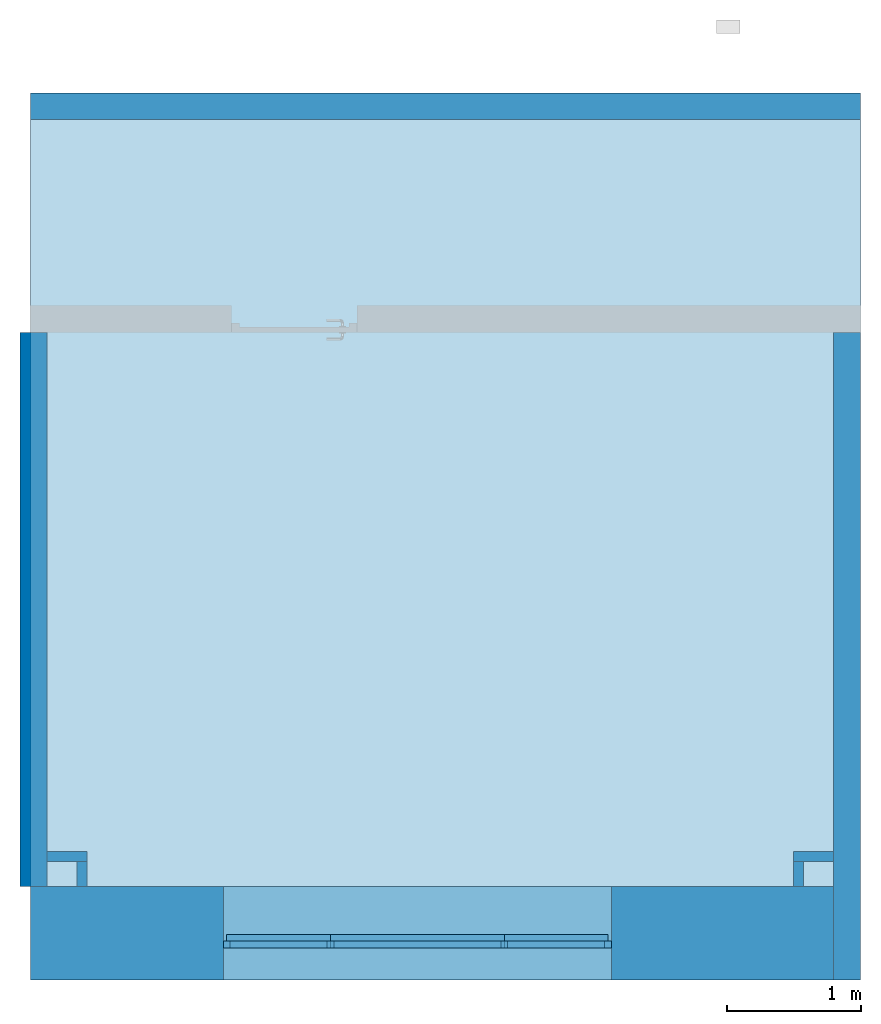
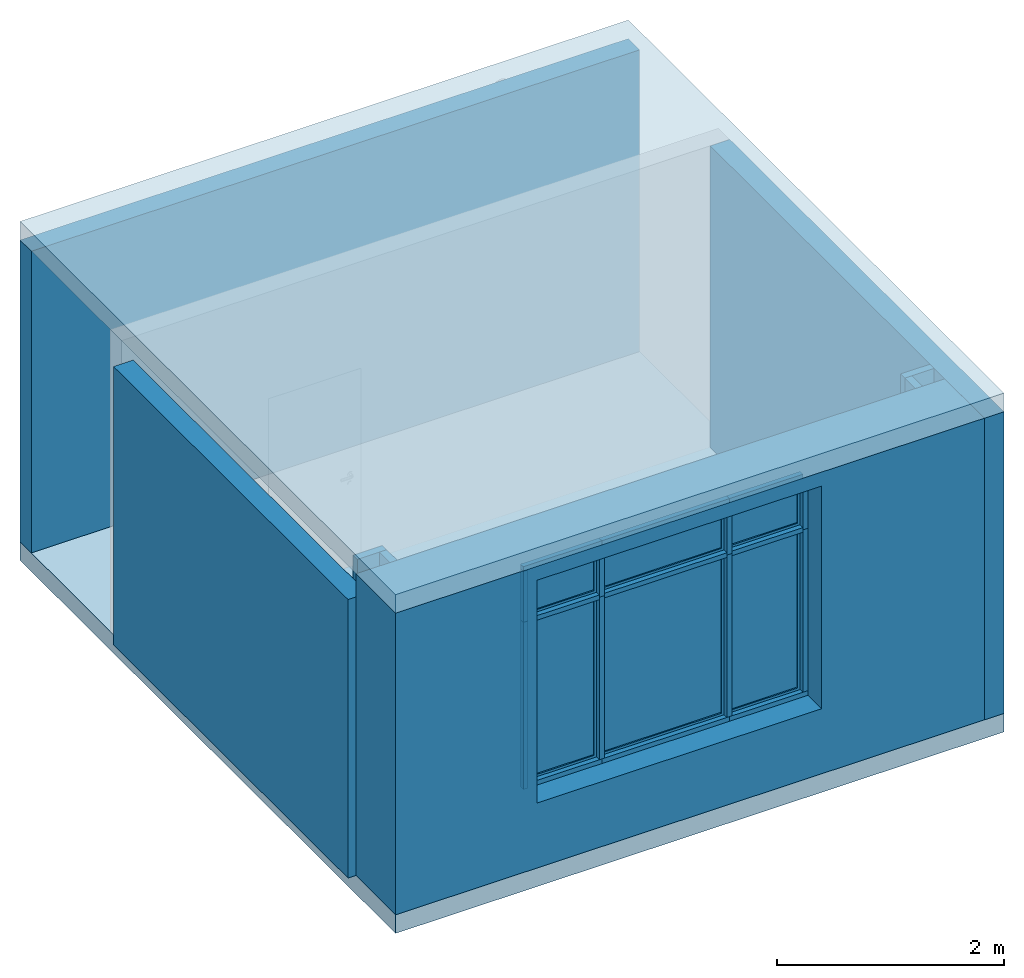
# One storey, part 1 of 4: 17 members, 8 walls, 6 plates, 2 slabs, 1 opening, 1 element without a shape of its own.
"""IFC2X3 building model written with IfcOpenShell, lengths in millimetres."""

from ifc_helpers import new_model, entity, si_unit, converted_unit, derived_unit, direction, frame, frame_2d, origin, origin_2d_with_axis, place, context, subcontext, project, spatial, polyline, rectangle, outline, extrude, clip, bounded_halfspace, source, transform, mapped, material, material_list, layer, layer_set, layer_usage, type_object, type_shapes, element, aggregate, save


model = new_model("IFC2X3")

# Units and contexts
model_context = context("Model", 3, precision=0.01, world=origin(), true_north=direction((6.123233995736766e-17, 1.0)))
body_context = subcontext(model_context, "Body", "Model", "MODEL_VIEW")
ifc_project = project(units=[si_unit("LENGTHUNIT", "METRE", prefix="MILLI"), si_unit("AREAUNIT", "SQUARE_METRE"), si_unit("VOLUMEUNIT", "CUBIC_METRE"), converted_unit("PLANEANGLEUNIT", "DEGREE", entity("IfcPlaneAngleMeasure", 0.017453292519943278), si_unit("PLANEANGLEUNIT", "RADIAN"), dimensions=[0, 0, 0, 0, 0, 0, 0]), derived_unit("THERMALTRANSMITTANCEUNIT", [(si_unit("MASSUNIT", "GRAM", prefix="KILO"), 1), (si_unit("THERMODYNAMICTEMPERATUREUNIT", "KELVIN"), -1), (si_unit("TIMEUNIT", "SECOND"), -3)])], contexts=[model_context])

# Site, building, storey
site_placement = place(None, origin())
site = spatial("IfcSite", under=ifc_project, at=site_placement, CompositionType="ELEMENT")
building_placement = place(site_placement, origin())
building = spatial("IfcBuilding", under=site, at=building_placement, CompositionType="ELEMENT")
storey_placement = place(building_placement, origin())
storey = spatial("IfcBuildingStorey", under=building, at=storey_placement, CompositionType="ELEMENT", Elevation=0.0)

# Curtain wall, members
curtain_wall_type = type_object("IfcCurtainWallType", PredefinedType="NOTDEFINED")
curtain_wall_placement = place(storey_placement, origin())
curtain_wall = element("IfcCurtainWall", 1, at=curtain_wall_placement, inside=storey, type_object=curtain_wall_type)
ifc_material_1 = material(Name="Aluminium, RAL 7021")
member_type_1 = type_object("IfcMemberType", Name="Rectangular Mullion:50x50, RAL 7021", PredefinedType="MULLION", material=ifc_material_1)
shared_shape_1 = source(origin(), body_context, "Body", "SweptSolid", [
    extrude(rectangle(XDim=50.0, YDim=50.000000000000014, at=origin_2d_with_axis()), frame((-25.0, 0.0, -750.0), z_axis=(0.0, 0.0, 1.0), x_axis=(-1.0, 0.0, 0.0)), (0.0, 0.0, 1.0), 750.0),
])
type_shapes(member_type_1, [shared_shape_1])
member_1_placement = place(curtain_wall_placement, frame((10300.0, -435.0, 3100.0), z_axis=(1.0, 0.0, 0.0), x_axis=(0.0, 0.0, 1.0)))
member_1 = element("IfcMember", 2, at=member_1_placement, type_object=member_type_1, material=ifc_material_1, Name="Rectangular Mullion:50x50, RAL 7021", ObjectType="Rectangular Mullion:50x50, RAL 7021", context=body_context, shape_type="MappedRepresentation", body=[
    mapped(shared_shape_1, transform((0.0, 0.0, 0.0), scale=1.0)),
])
member_type_2 = type_object("IfcMemberType", Name="Rectangular Mullion:50x50, RAL 7021", PredefinedType="MULLION", material=ifc_material_1)
shared_shape_2 = source(origin(), body_context, "Body", "SweptSolid", [
    extrude(rectangle(XDim=50.0, YDim=50.000000000000014, at=origin_2d_with_axis()), frame((-25.0, 0.0, -750.0), z_axis=(0.0, 0.0, 1.0), x_axis=(-1.0, 0.0, 0.0)), (0.0, 0.0, 1.0), 750.0),
])
type_shapes(member_type_2, [shared_shape_2])
member_2_placement = place(curtain_wall_placement, frame((7500.0, -435.0, 700.0), z_axis=(-1.0, 0.0, 0.0), x_axis=(0.0, 0.0, -1.0)))
member_2 = element("IfcMember", 3, at=member_2_placement, type_object=member_type_2, material=ifc_material_1, Name="Rectangular Mullion:50x50, RAL 7021", ObjectType="Rectangular Mullion:50x50, RAL 7021", context=body_context, shape_type="MappedRepresentation", body=[
    mapped(shared_shape_2, transform((0.0, 0.0, 0.0), scale=1.0)),
])
member_type_3 = type_object("IfcMemberType", Name="Rectangular Mullion:50x50, RAL 7021", PredefinedType="MULLION", material=ifc_material_1)
shared_shape_3 = source(origin(), body_context, "Body", "SweptSolid", [
    extrude(rectangle(XDim=50.0, YDim=50.000000000000014, at=origin_2d_with_axis()), frame((-25.0, 0.0, -1750.0), z_axis=(0.0, 0.0, 1.0), x_axis=(-1.0, 0.0, 0.0)), (0.0, 0.0, 1.0), 1750.0000000000002),
])
type_shapes(member_type_3, [shared_shape_3])
member_3_placement = place(curtain_wall_placement, frame((10350.0, -435.0, 750.0), z_axis=(0.0, 0.0, -1.0), x_axis=(1.0, 0.0, 0.0)))
member_3 = element("IfcMember", 4, at=member_3_placement, type_object=member_type_3, material=ifc_material_1, Name="Rectangular Mullion:50x50, RAL 7021", ObjectType="Rectangular Mullion:50x50, RAL 7021", context=body_context, shape_type="MappedRepresentation", body=[
    mapped(shared_shape_3, transform((0.0, 0.0, 0.0), scale=1.0)),
])
member_type_4 = type_object("IfcMemberType", Name="Rectangular Mullion:50x50, RAL 7021", PredefinedType="MULLION", material=ifc_material_1)
shared_shape_4 = source(origin(), body_context, "Body", "SweptSolid", [
    extrude(rectangle(XDim=50.0, YDim=50.0, at=origin_2d_with_axis()), frame((-25.0, 0.0, -550.0), z_axis=(0.0, 0.0, 1.0), x_axis=(-1.0, 0.0, 0.0)), (0.0, 0.0, 1.0), 550.0),
])
type_shapes(member_type_4, [shared_shape_4])
member_4_placement = place(curtain_wall_placement, frame((7450.0, -435.0, 3050.0), z_axis=(0.0, 0.0, 1.0), x_axis=(-1.0, 0.0, 0.0)))
member_4 = element("IfcMember", 5, at=member_4_placement, type_object=member_type_4, material=ifc_material_1, Name="Rectangular Mullion:50x50, RAL 7021", ObjectType="Rectangular Mullion:50x50, RAL 7021", context=body_context, shape_type="MappedRepresentation", body=[
    mapped(shared_shape_4, transform((0.0, 0.0, 0.0), scale=1.0)),
])
member_type_5 = type_object("IfcMemberType", Name="Rectangular Mullion:50x50, RAL 7021", PredefinedType="MULLION", material=ifc_material_1)
shared_shape_5 = source(origin(), body_context, "Body", "SweptSolid", [
    extrude(rectangle(XDim=50.0, YDim=50.000000000000014, at=origin_2d_with_axis()), frame((-25.0, 0.0, -600.0), z_axis=(0.0, 0.0, 1.0), x_axis=(-1.0, 0.0, 0.0)), (0.0, 0.0, 1.0), 600.0),
])
type_shapes(member_type_5, [shared_shape_5])
member_5_placement = place(curtain_wall_placement, frame((10350.0, -435.0, 2500.0), z_axis=(0.0, 0.0, -1.0), x_axis=(1.0, 0.0, 0.0)))
member_5 = element("IfcMember", 6, at=member_5_placement, type_object=member_type_5, material=ifc_material_1, Name="Rectangular Mullion:50x50, RAL 7021", ObjectType="Rectangular Mullion:50x50, RAL 7021", context=body_context, shape_type="MappedRepresentation", body=[
    mapped(shared_shape_5, transform((0.0, 0.0, 0.0), scale=1.0)),
])
member_type_6 = type_object("IfcMemberType", Name="Rectangular Mullion:50x50, RAL 7021", PredefinedType="MULLION", material=ifc_material_1)
shared_shape_6 = source(origin(), body_context, "Body", "SweptSolid", [
    extrude(rectangle(XDim=50.0, YDim=50.0, at=origin_2d_with_axis()), frame((-25.0, 0.0, -1800.0), z_axis=(0.0, 0.0, 1.0), x_axis=(-1.0, 0.0, 0.0)), (0.0, 0.0, 1.0), 1800.0000000000002),
])
type_shapes(member_type_6, [shared_shape_6])
member_6_placement = place(curtain_wall_placement, frame((7450.0, -435.0, 2500.0), z_axis=(0.0, 0.0, 1.0), x_axis=(-1.0, 0.0, 0.0)))
member_6 = element("IfcMember", 7, at=member_6_placement, type_object=member_type_6, material=ifc_material_1, Name="Rectangular Mullion:50x50, RAL 7021", ObjectType="Rectangular Mullion:50x50, RAL 7021", context=body_context, shape_type="MappedRepresentation", body=[
    mapped(shared_shape_6, transform((0.0, 0.0, 0.0), scale=1.0)),
])
member_type_7 = type_object("IfcMemberType", Name="Rectangular Mullion:50x50, RAL 7021", PredefinedType="MULLION", material=ifc_material_1)
shared_shape_7 = source(origin(), body_context, "Body", "SweptSolid", [
    extrude(rectangle(XDim=50.0, YDim=50.0, at=frame_2d((0.0, 1.7763568394002505e-15), x_axis=(1.0, 0.0))), frame((0.0, 0.0, -725.0), z_axis=(0.0, 0.0, 1.0), x_axis=(-1.0, 0.0, 0.0)), (0.0, 0.0, 1.0), 725.0),
])
type_shapes(member_type_7, [shared_shape_7])
member_7_placement = place(curtain_wall_placement, frame((8225.0, -435.0, 2500.0), z_axis=(1.0, 0.0, 0.0), x_axis=(0.0, 0.0, 1.0)))
member_7 = element("IfcMember", 8, at=member_7_placement, type_object=member_type_7, material=ifc_material_1, Name="Rectangular Mullion:50x50, RAL 7021", ObjectType="Rectangular Mullion:50x50, RAL 7021", context=body_context, shape_type="MappedRepresentation", body=[
    mapped(shared_shape_7, transform((0.0, 0.0, 0.0), scale=1.0)),
])
member_8_placement = place(curtain_wall_placement, frame((10300.0, -435.0, 2500.0), z_axis=(1.0, 0.0, 0.0), x_axis=(0.0, 0.0, 1.0)))
member_8 = element("IfcMember", 9, at=member_8_placement, type_object=member_type_7, material=ifc_material_1, Name="Rectangular Mullion:50x50, RAL 7021", ObjectType="Rectangular Mullion:50x50, RAL 7021", context=body_context, shape_type="MappedRepresentation", body=[
    mapped(shared_shape_7, transform((0.0, 0.0, 0.0), scale=1.0)),
])
member_type_8 = type_object("IfcMemberType", Name="Rectangular Mullion:50x50, RAL 7021", PredefinedType="MULLION", material=ifc_material_1)
shared_shape_8 = source(origin(), body_context, "Body", "SweptSolid", [
    extrude(rectangle(XDim=50.0, YDim=50.000000000000014, at=origin_2d_with_axis()), frame((-25.0, 0.0, -800.0), z_axis=(0.0, 0.0, 1.0), x_axis=(-1.0, 0.0, 0.0)), (0.0, 0.0, 1.0), 800.0),
])
type_shapes(member_type_8, [shared_shape_8])
member_9_placement = place(curtain_wall_placement, frame((8250.0, -435.0, 3100.0), z_axis=(1.0, 0.0, 0.0), x_axis=(0.0, 0.0, 1.0)))
member_9 = element("IfcMember", 10, at=member_9_placement, type_object=member_type_8, material=ifc_material_1, Name="Rectangular Mullion:50x50, RAL 7021", ObjectType="Rectangular Mullion:50x50, RAL 7021", context=body_context, shape_type="MappedRepresentation", body=[
    mapped(shared_shape_8, transform((0.0, 0.0, 0.0), scale=1.0)),
])
member_type_9 = type_object("IfcMemberType", Name="Rectangular Mullion:50x50, RAL 7021", PredefinedType="MULLION", material=ifc_material_1)
shared_shape_9 = source(origin(), body_context, "Body", "SweptSolid", [
    extrude(rectangle(XDim=50.0, YDim=50.000000000000014, at=origin_2d_with_axis()), frame((-25.0, 0.0, -1300.0), z_axis=(0.0, 0.0, 1.0), x_axis=(-1.0, 0.0, 0.0)), (0.0, 0.0, 1.0), 1300.0),
])
type_shapes(member_type_9, [shared_shape_9])
member_10_placement = place(curtain_wall_placement, frame((8250.0, -435.0, 700.0), z_axis=(-1.0, 0.0, 0.0), x_axis=(0.0, 0.0, -1.0)))
member_10 = element("IfcMember", 11, at=member_10_placement, type_object=member_type_9, material=ifc_material_1, Name="Rectangular Mullion:50x50, RAL 7021", ObjectType="Rectangular Mullion:50x50, RAL 7021", context=body_context, shape_type="MappedRepresentation", body=[
    mapped(shared_shape_9, transform((0.0, 0.0, 0.0), scale=1.0)),
])
member_type_10 = type_object("IfcMemberType", Name="Rectangular Mullion:50x50, RAL 7021", PredefinedType="MULLION", material=ifc_material_1)
shared_shape_10 = source(origin(), body_context, "Body", "SweptSolid", [
    extrude(rectangle(XDim=50.0, YDim=50.0, at=frame_2d((0.0, 1.7763568394002505e-15), x_axis=(1.0, 0.0))), frame((0.0, 0.0, -1250.0), z_axis=(0.0, 0.0, 1.0), x_axis=(-1.0, 0.0, 0.0)), (0.0, 0.0, 1.0), 1250.0),
])
type_shapes(member_type_10, [shared_shape_10])
member_11_placement = place(curtain_wall_placement, frame((9525.0, -435.0, 2500.0), z_axis=(1.0, 0.0, 0.0), x_axis=(0.0, 0.0, 1.0)))
member_11 = element("IfcMember", 12, at=member_11_placement, type_object=member_type_10, material=ifc_material_1, Name="Rectangular Mullion:50x50, RAL 7021", ObjectType="Rectangular Mullion:50x50, RAL 7021", context=body_context, shape_type="MappedRepresentation", body=[
    mapped(shared_shape_10, transform((0.0, 0.0, 0.0), scale=1.0)),
])
member_type_11 = type_object("IfcMemberType", Name="Rectangular Mullion:50x50, RAL 7021", PredefinedType="MULLION", material=ifc_material_1)
shared_shape_11 = source(origin(), body_context, "Body", "SweptSolid", [
    extrude(rectangle(XDim=50.0, YDim=50.0, at=origin_2d_with_axis()), frame((0.0, 0.0, -1750.0), z_axis=(0.0, 0.0, 1.0), x_axis=(-1.0, 0.0, 0.0)), (0.0, 0.0, 1.0), 1750.0000000000002),
])
type_shapes(member_type_11, [shared_shape_11])
member_12_placement = place(curtain_wall_placement, frame((8250.0, -435.0, 750.0), z_axis=(0.0, 0.0, -1.0), x_axis=(1.0, 0.0, 0.0)))
member_12 = element("IfcMember", 13, at=member_12_placement, type_object=member_type_11, material=ifc_material_1, Name="Rectangular Mullion:50x50, RAL 7021", ObjectType="Rectangular Mullion:50x50, RAL 7021", context=body_context, shape_type="MappedRepresentation", body=[
    mapped(shared_shape_11, transform((0.0, 0.0, 0.0), scale=1.0)),
])
member_13_placement = place(curtain_wall_placement, frame((9550.0, -435.0, 750.0), z_axis=(0.0, 0.0, -1.0), x_axis=(1.0, 0.0, 0.0)))
member_13 = element("IfcMember", 14, at=member_13_placement, type_object=member_type_11, material=ifc_material_1, Name="Rectangular Mullion:50x50, RAL 7021", ObjectType="Rectangular Mullion:50x50, RAL 7021", context=body_context, shape_type="MappedRepresentation", body=[
    mapped(shared_shape_11, transform((0.0, 0.0, 0.0), scale=1.0)),
])
member_type_12 = type_object("IfcMemberType", Name="Rectangular Mullion:50x50, RAL 7021", PredefinedType="MULLION", material=ifc_material_1)
shared_shape_12 = source(origin(), body_context, "Body", "SweptSolid", [
    extrude(rectangle(XDim=50.0, YDim=50.0, at=origin_2d_with_axis()), frame((0.0, 0.0, -550.0), z_axis=(0.0, 0.0, 1.0), x_axis=(-1.0, 0.0, 0.0)), (0.0, 0.0, 1.0), 550.0),
])
type_shapes(member_type_12, [shared_shape_12])
member_14_placement = place(curtain_wall_placement, frame((8250.0, -435.0, 2500.0), z_axis=(0.0, 0.0, -1.0), x_axis=(1.0, 0.0, 0.0)))
member_14 = element("IfcMember", 15, at=member_14_placement, type_object=member_type_12, material=ifc_material_1, Name="Rectangular Mullion:50x50, RAL 7021", ObjectType="Rectangular Mullion:50x50, RAL 7021", context=body_context, shape_type="MappedRepresentation", body=[
    mapped(shared_shape_12, transform((0.0, 0.0, 0.0), scale=1.0)),
])
member_15_placement = place(curtain_wall_placement, frame((9550.0, -435.0, 2500.0), z_axis=(0.0, 0.0, -1.0), x_axis=(1.0, 0.0, 0.0)))
member_15 = element("IfcMember", 16, at=member_15_placement, type_object=member_type_12, material=ifc_material_1, Name="Rectangular Mullion:50x50, RAL 7021", ObjectType="Rectangular Mullion:50x50, RAL 7021", context=body_context, shape_type="MappedRepresentation", body=[
    mapped(shared_shape_12, transform((0.0, 0.0, 0.0), scale=1.0)),
])
member_type_13 = type_object("IfcMemberType", Name="Rectangular Mullion:50x50, RAL 7021", PredefinedType="MULLION", material=ifc_material_1)
shared_shape_13 = source(origin(), body_context, "Body", "SweptSolid", [
    extrude(rectangle(XDim=50.0, YDim=50.000000000000014, at=origin_2d_with_axis()), frame((-25.0, 0.0, -1300.0), z_axis=(0.0, 0.0, 1.0), x_axis=(-1.0, 0.0, 0.0)), (0.0, 0.0, 1.0), 1300.0),
])
type_shapes(member_type_13, [shared_shape_13])
member_16_placement = place(curtain_wall_placement, frame((9550.0, -435.0, 3100.0), z_axis=(1.0, 0.0, 0.0), x_axis=(0.0, 0.0, 1.0)))
member_16 = element("IfcMember", 17, at=member_16_placement, type_object=member_type_13, material=ifc_material_1, Name="Rectangular Mullion:50x50, RAL 7021", ObjectType="Rectangular Mullion:50x50, RAL 7021", context=body_context, shape_type="MappedRepresentation", body=[
    mapped(shared_shape_13, transform((0.0, 0.0, 0.0), scale=1.0)),
])
member_type_14 = type_object("IfcMemberType", Name="Rectangular Mullion:50x50, RAL 7021", PredefinedType="MULLION", material=ifc_material_1)
shared_shape_14 = source(origin(), body_context, "Body", "SweptSolid", [
    extrude(rectangle(XDim=50.0, YDim=50.000000000000014, at=origin_2d_with_axis()), frame((-25.0, 0.0, -800.0), z_axis=(0.0, 0.0, 1.0), x_axis=(-1.0, 0.0, 0.0)), (0.0, 0.0, 1.0), 800.0),
])
type_shapes(member_type_14, [shared_shape_14])
member_17_placement = place(curtain_wall_placement, frame((9550.0, -435.0, 700.0), z_axis=(-1.0, 0.0, 0.0), x_axis=(0.0, 0.0, -1.0)))
member_17 = element("IfcMember", 18, at=member_17_placement, type_object=member_type_14, material=ifc_material_1, Name="Rectangular Mullion:50x50, RAL 7021", ObjectType="Rectangular Mullion:50x50, RAL 7021", context=body_context, shape_type="MappedRepresentation", body=[
    mapped(shared_shape_14, transform((0.0, 0.0, 0.0), scale=1.0)),
])

# Slabs
ifc_material_2 = material()
ifc_layer_1 = layer(ifc_material_2, 200.0)
ifc_layer_set_1 = layer_set([ifc_layer_1])
ifc_layer_usage_1 = layer_usage(ifc_layer_set_1, "AXIS3", "POSITIVE", 0.0)
slab_type = type_object("IfcSlabType", PredefinedType="FLOOR", material=ifc_layer_set_1)
slab_1_placement = place(storey_placement, origin())
element("IfcSlab", 19, at=slab_1_placement, inside=storey, type_object=slab_type, material=ifc_layer_usage_1, PredefinedType="FLOOR", context=body_context, shape_type="SweptSolid", body=[
    extrude(rectangle(XDim=6630.000000000012, YDim=6200.000000000009, at=frame_2d((0.0, 1.1368683772161603e-12), x_axis=(1.0, 0.0))), frame((9110.0, 2615.0, 3450.0), z_axis=(0.0, 0.0, -1.0), x_axis=(0.0, 1.0, 0.0)), (0.0, 0.0, 1.0), 200.0),
])
ifc_layer_usage_2 = layer_usage(ifc_layer_set_1, "AXIS3", "POSITIVE", 0.0)
slab_2_placement = place(storey_placement, origin())
element("IfcSlab", 20, at=slab_2_placement, inside=storey, type_object=slab_type, material=ifc_layer_usage_2, PredefinedType="FLOOR", context=body_context, shape_type="SweptSolid", body=[
    extrude(rectangle(XDim=6630.000000000012, YDim=6200.000000000009, at=frame_2d((0.0, 1.1368683772161603e-12), x_axis=(1.0, 0.0))), frame((9110.0, 2615.0, 0.0), z_axis=(0.0, 0.0, -1.0), x_axis=(0.0, 1.0, 0.0)), (0.0, 0.0, 1.0), 200.0),
])

# Plate
ifc_material_3 = material(Name="Glass")
ifc_material_list = material_list([ifc_material_1, ifc_material_3])
plate_type_1 = type_object("IfcPlateType", Name="Casement panel:50x50, RAL 7021", PredefinedType="CURTAIN_PANEL", material=ifc_material_list)
shared_shape_15 = source(origin(), body_context, "Body", "SweptSolid", [
    extrude(outline(polyline([(-387.4999999999808, -887.4999999999947), (387.4999999999808, -887.4999999999947), (387.4999999999808, 887.4999999999947), (-387.4999999999808, 887.4999999999947), (-387.4999999999808, -887.4999999999947)]), holes=[polyline([(337.49999999998084, -837.4999999999917), (-337.4999999999802, -837.4999999999917), (-337.4999999999801, 837.4999999999957), (337.4999999999808, 837.4999999999957), (337.49999999998084, -837.4999999999917)])]), frame((0.0, 25.0, 862.4999999999984), z_axis=(0.0, 1.0, 0.0), x_axis=(-1.0, 0.0, 0.0)), (0.0, 0.0, 1.0), 50.0),
    extrude(rectangle(XDim=5.000000000000005, YDim=674.9999999999611, at=frame_2d((-4.218847493575595e-15, -5.684341886080802e-14), x_axis=(1.0, 0.0))), frame((0.0, 41.666666666664774, 25.0), z_axis=(0.0, 0.0, 1.0), x_axis=(0.0, 1.0, 0.0)), (0.0, 0.0, 1.0), 1674.9999999999877),
    extrude(rectangle(XDim=4.999999999999997, YDim=674.9999999999611, at=frame_2d((8.43769498715119e-15, -5.684341886080802e-14), x_axis=(1.0, 0.0))), frame((0.0, 58.33333333333141, 25.0), z_axis=(0.0, 0.0, 1.0), x_axis=(0.0, 1.0, 0.0)), (0.0, 0.0, 1.0), 1674.9999999999877),
])
type_shapes(plate_type_1, [shared_shape_15])
plate_1_placement = place(curtain_wall_placement, frame((7862.50000000001, -435.0, 750.0)))
plate_1 = element("IfcPlate", 21, at=plate_1_placement, type_object=plate_type_1, material=ifc_material_list, Name="Casement panel:50x50, RAL 7021", ObjectType="Casement panel:50x50, RAL 7021", context=body_context, shape_type="MappedRepresentation", body=[
    mapped(shared_shape_15, transform((0.0, 0.0, 0.0), scale=1.0)),
])

plate_2_placement = place(curtain_wall_placement, frame((9937.500000000011, -435.0, 750.0)))
plate_2 = element("IfcPlate", 22, at=plate_2_placement, type_object=plate_type_1, material=ifc_material_list, Name="Casement panel:50x50, RAL 7021", ObjectType="Casement panel:50x50, RAL 7021", context=body_context, shape_type="MappedRepresentation", body=[
    mapped(shared_shape_15, transform((0.0, 0.0, 0.0), scale=1.0)),
])

plate_type_2 = type_object("IfcPlateType", Name="Casement panel:50x50, RAL 7021", PredefinedType="CURTAIN_PANEL", material=ifc_material_list)
shared_shape_16 = source(origin(), body_context, "Body", "SweptSolid", [
    extrude(outline(polyline([(-650.0, -887.4999999999947), (650.0, -887.4999999999947), (650.0, 887.4999999999947), (-650.0, 887.4999999999947), (-650.0, -887.4999999999947)]), holes=[polyline([(600.0, -837.4999999999917), (-600.0, -837.4999999999917), (-600.0, 837.4999999999957), (600.0, 837.4999999999957), (600.0, -837.4999999999917)])]), frame((0.0, 25.0, 862.4999999999984), z_axis=(0.0, 1.0, 0.0), x_axis=(-1.0, 0.0, 0.0)), (0.0, 0.0, 1.0), 50.0),
    extrude(rectangle(XDim=5.000000000000005, YDim=1199.9999999999611, at=frame_2d((-4.218847493575595e-15, 0.0), x_axis=(1.0, 0.0))), frame((0.0, 41.666666666664774, 25.0), z_axis=(0.0, 0.0, 1.0), x_axis=(0.0, 1.0, 0.0)), (0.0, 0.0, 1.0), 1674.9999999999877),
    extrude(rectangle(XDim=4.999999999999997, YDim=1199.9999999999611, at=frame_2d((8.43769498715119e-15, 0.0), x_axis=(1.0, 0.0))), frame((0.0, 58.33333333333141, 25.0), z_axis=(0.0, 0.0, 1.0), x_axis=(0.0, 1.0, 0.0)), (0.0, 0.0, 1.0), 1674.9999999999877),
])
type_shapes(plate_type_2, [shared_shape_16])
plate_3_placement = place(curtain_wall_placement, frame((8900.0, -435.0, 750.0)))
plate_3 = element("IfcPlate", 23, at=plate_3_placement, type_object=plate_type_2, material=ifc_material_list, Name="Casement panel:50x50, RAL 7021", ObjectType="Casement panel:50x50, RAL 7021", context=body_context, shape_type="MappedRepresentation", body=[
    mapped(shared_shape_16, transform((0.0, 0.0, 0.0), scale=1.0)),
])

plate_type_3 = type_object("IfcPlateType", Name="Casement panel:50x50, RAL 7021", PredefinedType="CURTAIN_PANEL", material=ifc_material_list)
shared_shape_17 = source(origin(), body_context, "Body", "SweptSolid", [
    extrude(outline(polyline([(-387.4999999999808, -287.4999999999946), (387.4999999999808, -287.4999999999946), (387.4999999999808, 287.4999999999946), (-387.4999999999808, 287.4999999999946), (-387.4999999999808, -287.4999999999946)]), holes=[polyline([(337.49999999998084, -237.49999999999176), (-337.4999999999802, -237.49999999999176), (-337.4999999999801, 237.49999999999568), (337.4999999999808, 237.49999999999568), (337.49999999998084, -237.49999999999176)])]), frame((0.0, 25.0, 262.49999999999847), z_axis=(0.0, 1.0, 0.0), x_axis=(-1.0, 0.0, 0.0)), (0.0, 0.0, 1.0), 50.0),
    extrude(rectangle(XDim=5.000000000000005, YDim=674.9999999999611, at=frame_2d((-4.218847493575595e-15, -5.684341886080802e-14), x_axis=(1.0, 0.0))), frame((0.0, 41.666666666664774, 25.0), z_axis=(0.0, 0.0, 1.0), x_axis=(0.0, 1.0, 0.0)), (0.0, 0.0, 1.0), 474.99999999998755),
    extrude(rectangle(XDim=4.999999999999997, YDim=674.9999999999611, at=frame_2d((8.43769498715119e-15, -5.684341886080802e-14), x_axis=(1.0, 0.0))), frame((0.0, 58.33333333333141, 25.0), z_axis=(0.0, 0.0, 1.0), x_axis=(0.0, 1.0, 0.0)), (0.0, 0.0, 1.0), 474.99999999998755),
])
type_shapes(plate_type_3, [shared_shape_17])
plate_4_placement = place(curtain_wall_placement, frame((7862.50000000001, -435.0, 2525.0)))
plate_4 = element("IfcPlate", 24, at=plate_4_placement, type_object=plate_type_3, material=ifc_material_list, Name="Casement panel:50x50, RAL 7021", ObjectType="Casement panel:50x50, RAL 7021", context=body_context, shape_type="MappedRepresentation", body=[
    mapped(shared_shape_17, transform((0.0, 0.0, 0.0), scale=1.0)),
])

plate_5_placement = place(curtain_wall_placement, frame((9937.500000000011, -435.0, 2525.0)))
plate_5 = element("IfcPlate", 25, at=plate_5_placement, type_object=plate_type_3, material=ifc_material_list, Name="Casement panel:50x50, RAL 7021", ObjectType="Casement panel:50x50, RAL 7021", context=body_context, shape_type="MappedRepresentation", body=[
    mapped(shared_shape_17, transform((0.0, 0.0, 0.0), scale=1.0)),
])

plate_type_4 = type_object("IfcPlateType", Name="Casement panel:50x50, RAL 7021", PredefinedType="CURTAIN_PANEL", material=ifc_material_list)
shared_shape_18 = source(origin(), body_context, "Body", "SweptSolid", [
    extrude(outline(polyline([(-650.0, -287.4999999999946), (650.0, -287.4999999999946), (650.0, 287.4999999999946), (-650.0, 287.4999999999946), (-650.0, -287.4999999999946)]), holes=[polyline([(600.0, -237.49999999999176), (-600.0, -237.49999999999176), (-600.0, 237.49999999999568), (600.0, 237.49999999999568), (600.0, -237.49999999999176)])]), frame((0.0, 25.0, 262.49999999999847), z_axis=(0.0, 1.0, 0.0), x_axis=(-1.0, 0.0, 0.0)), (0.0, 0.0, 1.0), 50.0),
    extrude(rectangle(XDim=5.000000000000005, YDim=1199.9999999999611, at=frame_2d((-4.218847493575595e-15, 0.0), x_axis=(1.0, 0.0))), frame((0.0, 41.666666666664774, 25.0), z_axis=(0.0, 0.0, 1.0), x_axis=(0.0, 1.0, 0.0)), (0.0, 0.0, 1.0), 474.99999999998755),
    extrude(rectangle(XDim=4.999999999999997, YDim=1199.9999999999611, at=frame_2d((8.43769498715119e-15, 0.0), x_axis=(1.0, 0.0))), frame((0.0, 58.33333333333141, 25.0), z_axis=(0.0, 0.0, 1.0), x_axis=(0.0, 1.0, 0.0)), (0.0, 0.0, 1.0), 474.99999999998755),
])
type_shapes(plate_type_4, [shared_shape_18])
plate_6_placement = place(curtain_wall_placement, frame((8900.0, -435.0, 2525.0)))
plate_6 = element("IfcPlate", 26, at=plate_6_placement, type_object=plate_type_4, material=ifc_material_list, Name="Casement panel:50x50, RAL 7021", ObjectType="Casement panel:50x50, RAL 7021", context=body_context, shape_type="MappedRepresentation", body=[
    mapped(shared_shape_18, transform((0.0, 0.0, 0.0), scale=1.0)),
])

aggregate(curtain_wall, [plate_1, plate_3, plate_2, plate_4, plate_6, plate_5, member_1, member_2, member_3, member_4, member_5, member_6, member_7, member_9, member_10, member_11, member_12, member_14, member_16, member_17, member_8, member_13, member_15])

# Wall, opening
ifc_layer_2 = layer(ifc_material_2, 700.0)
ifc_layer_set_2 = layer_set([ifc_layer_2])
ifc_layer_usage_3 = layer_usage(ifc_layer_set_2, "AXIS2", "NEGATIVE", 350.0)
wall_type_1 = type_object("IfcWallType", PredefinedType="STANDARD", material=ifc_layer_set_2)
wall_1_placement = place(storey_placement, frame((6010.0, -350.0, 0.0)))
wall_1 = element("IfcWallStandardCase", 27, at=wall_1_placement, inside=storey, type_object=wall_type_1, material=ifc_layer_usage_3, context=body_context, shape_type="Clipping", body=[
    clip(extrude(rectangle(XDim=6000.000000000007, YDim=700.0, at=frame_2d((3000.0000000000036, 0.0), x_axis=(-1.0, 0.0))), origin(), (0.0, 0.0, 1.0), 3250.0), bounded_halfspace(frame((0.0, -350.0, 3250.0), z_axis=(0.0, 0.0, -1.0), x_axis=(0.0, -1.0, 0.0)), True, frame((0.0, -350.0, 3250.0)), polyline([(0.0, 0.0), (6000.0, 0.0), (6000.0, 700.0), (5775.0, 700.0), (5700.0, 700.0), (420.0, 700.0), (345.0, 700.0), (0.0, 700.0), (0.0, 0.0)]))),
])
opening_placement = place(wall_1_placement, origin())
element("IfcOpeningElement", 28, at=opening_placement, cuts=wall_1, ObjectType="Opening", context=body_context, shape_type="SweptSolid", body=[
    extrude(rectangle(XDim=2400.0, YDim=2900.0000000000014, at=origin_2d_with_axis()), frame((2890.0, -502.40000000000003, 1900.0), z_axis=(0.0, 1.0, 0.0), x_axis=(0.0, 0.0, 1.0)), (0.0, 0.0, 1.0), 1004.8000000000001),
])

# Walls
ifc_layer_3 = layer(ifc_material_2, 200.0)
ifc_layer_set_3 = layer_set([ifc_layer_3])
ifc_layer_usage_4 = layer_usage(ifc_layer_set_3, "AXIS2", "NEGATIVE", 100.0)
wall_type_2 = type_object("IfcWallType", PredefinedType="STANDARD", material=ifc_layer_set_3)
wall_2_placement = place(storey_placement, frame((6030.0, 0.0, 0.0), z_axis=(0.0, 0.0, 1.0), x_axis=(0.0, 1.0, 0.0)))
element("IfcWallStandardCase", 29, at=wall_2_placement, inside=storey, type_object=wall_type_2, material=ifc_layer_usage_4, context=body_context, shape_type="SweptSolid", body=[
    extrude(rectangle(XDim=4140.00000000001, YDim=200.0, at=frame_2d((2070.000000000005, -1.2079226507921703e-13), x_axis=(-1.0, 0.0))), origin(), (0.0, 0.0, 1.0), 3000.0),
])
ifc_layer_usage_5 = layer_usage(ifc_layer_set_3, "AXIS2", "NEGATIVE", 100.0)
wall_3_placement = place(storey_placement, frame((12110.0, 4140.0, 0.0), z_axis=(0.0, 0.0, 1.0), x_axis=(0.0, -1.0, 0.0)))
element("IfcWallStandardCase", 30, at=wall_3_placement, inside=storey, type_object=wall_type_2, material=ifc_layer_usage_5, context=body_context, shape_type="Clipping", body=[
    clip(extrude(rectangle(XDim=4840.000000000011, YDim=200.00000000000216, at=frame_2d((2420.0000000000055, 3.694822225952521e-13), x_axis=(-1.0, 0.0))), origin(), (0.0, 0.0, 1.0), 3250.0), bounded_halfspace(frame((0.0, -100.0, 3250.0), z_axis=(0.0, 0.0, -1.0), x_axis=(1.0, 0.0, 0.0)), True, frame((0.0, -100.0, 3250.0)), polyline([(0.0, 0.0), (3880.0, 0.0), (3955.0, 0.0), (4140.0, 0.0), (4840.0, 0.0), (4840.0, 200.0), (0.0, 200.0), (0.0, 0.0)]))),
])
ifc_layer_usage_6 = layer_usage(ifc_layer_set_3, "AXIS2", "NEGATIVE", 100.0)
wall_4_placement = place(storey_placement, frame((12210.0, 5830.0, 0.0), z_axis=(0.0, 0.0, 1.0), x_axis=(-1.0, 0.0, 0.0)))
element("IfcWallStandardCase", 31, at=wall_4_placement, inside=storey, type_object=wall_type_2, material=ifc_layer_usage_6, context=body_context, shape_type="SweptSolid", body=[
    extrude(rectangle(XDim=6200.0000000000155, YDim=200.0, at=frame_2d((3100.0000000000077, 0.0), x_axis=(-1.0, 0.0))), origin(), (0.0, 0.0, 1.0), 3250.0),
])
ifc_material_4 = material()
ifc_layer_4 = layer(ifc_material_4, 12.5)
ifc_material_5 = material()
ifc_layer_5 = layer(ifc_material_5, 50.0)
ifc_layer_6 = layer(ifc_material_4, 12.5)
ifc_layer_set_4 = layer_set([ifc_layer_4, ifc_layer_5, ifc_layer_6])
ifc_layer_usage_7 = layer_usage(ifc_layer_set_4, "AXIS2", "NEGATIVE", 37.49999999999999)
wall_type_3 = type_object("IfcWallType", PredefinedType="STANDARD", material=ifc_layer_set_4)
wall_5_placement = place(storey_placement, frame((12010.0, 222.49999999996115, 0.0), z_axis=(0.0, 0.0, 1.0), x_axis=(-1.0, 0.0, 0.0)))
element("IfcWallStandardCase", 32, at=wall_5_placement, inside=storey, type_object=wall_type_3, material=ifc_layer_usage_7, context=body_context, shape_type="Clipping", body=[
    clip(extrude(rectangle(XDim=299.99999999999676, YDim=75.0, at=frame_2d((149.99999999999838, -3.552713678800501e-15), x_axis=(-1.0, 0.0))), origin(), (0.0, 0.0, 1.0), 3250.0), bounded_halfspace(frame((0.0, -37.49999999999997, 3250.0), z_axis=(0.0, 0.0, -1.0), x_axis=(0.0, 1.0, 0.0)), True, frame((0.0, -37.49999999999997, 3250.0)), polyline([(0.0, 0.0), (300.0, 0.0), (300.0, 75.0), (225.0, 75.0), (0.0, 75.0), (0.0, 0.0)]))),
])
ifc_layer_usage_8 = layer_usage(ifc_layer_set_4, "AXIS2", "NEGATIVE", 37.49999999999999)
wall_6_placement = place(storey_placement, frame((11747.500000000011, 185.0, 0.0), z_axis=(0.0, 0.0, 1.0), x_axis=(0.0, -1.0, 0.0)))
element("IfcWallStandardCase", 33, at=wall_6_placement, inside=storey, type_object=wall_type_3, material=ifc_layer_usage_8, context=body_context, shape_type="Clipping", body=[
    clip(extrude(rectangle(XDim=184.9999999999834, YDim=75.00000000000027, at=frame_2d((92.4999999999917, 0.0), x_axis=(-1.0, 0.0))), origin(), (0.0, 0.0, 1.0), 3250.0), bounded_halfspace(frame((0.0, -37.500000000000135, 3250.0), z_axis=(0.0, 0.0, -1.0), x_axis=(1.0, 0.0, 0.0)), True, frame((0.0, -37.500000000000135, 3250.0)), polyline([(0.0, 0.0), (185.0, 0.0), (185.0, 75.0), (0.0, 75.0), (0.0, 0.0)]))),
])
ifc_layer_usage_9 = layer_usage(ifc_layer_set_4, "AXIS2", "NEGATIVE", 37.49999999999999)
wall_7_placement = place(storey_placement, frame((6130.0, 222.4999999999802, 0.0)))
element("IfcWallStandardCase", 34, at=wall_7_placement, inside=storey, type_object=wall_type_3, material=ifc_layer_usage_9, context=body_context, shape_type="Clipping", body=[
    clip(extrude(rectangle(XDim=300.0000000000011, YDim=75.0, at=frame_2d((150.00000000000054, 7.105427357601002e-15), x_axis=(-1.0, 0.0))), origin(), (0.0, 0.0, 1.0), 3250.0), bounded_halfspace(frame((0.0, -37.49999999999997, 3250.0), z_axis=(0.0, 0.0, -1.0), x_axis=(0.0, -1.0, 0.0)), True, frame((0.0, -37.49999999999997, 3250.0)), polyline([(0.0, 0.0), (225.0, 0.0), (300.0, 0.0), (300.0, 75.0), (0.0, 75.0), (0.0, 0.0)]))),
])
ifc_layer_usage_10 = layer_usage(ifc_layer_set_4, "AXIS2", "NEGATIVE", 37.49999999999999)
wall_8_placement = place(storey_placement, frame((6392.50000000001, 185.0, 0.0), z_axis=(0.0, 0.0, 1.0), x_axis=(0.0, -1.0, 0.0)))
element("IfcWallStandardCase", 35, at=wall_8_placement, inside=storey, type_object=wall_type_3, material=ifc_layer_usage_10, context=body_context, shape_type="Clipping", body=[
    clip(extrude(rectangle(XDim=185.00000000000068, YDim=75.00000000000028, at=frame_2d((92.50000000000034, 2.5224267119483557e-13), x_axis=(-1.0, 0.0))), origin(), (0.0, 0.0, 1.0), 3250.0), bounded_halfspace(frame((0.0, -37.50000000000064, 3250.0), z_axis=(0.0, 0.0, -1.0), x_axis=(1.0, 0.0, 0.0)), True, frame((0.0, -37.50000000000064, 3250.0)), polyline([(0.0, 0.0), (185.0, 0.0), (185.0, 75.0), (0.0, 75.0), (0.0, 0.0)]))),
])

save(model, "model.ifc")
